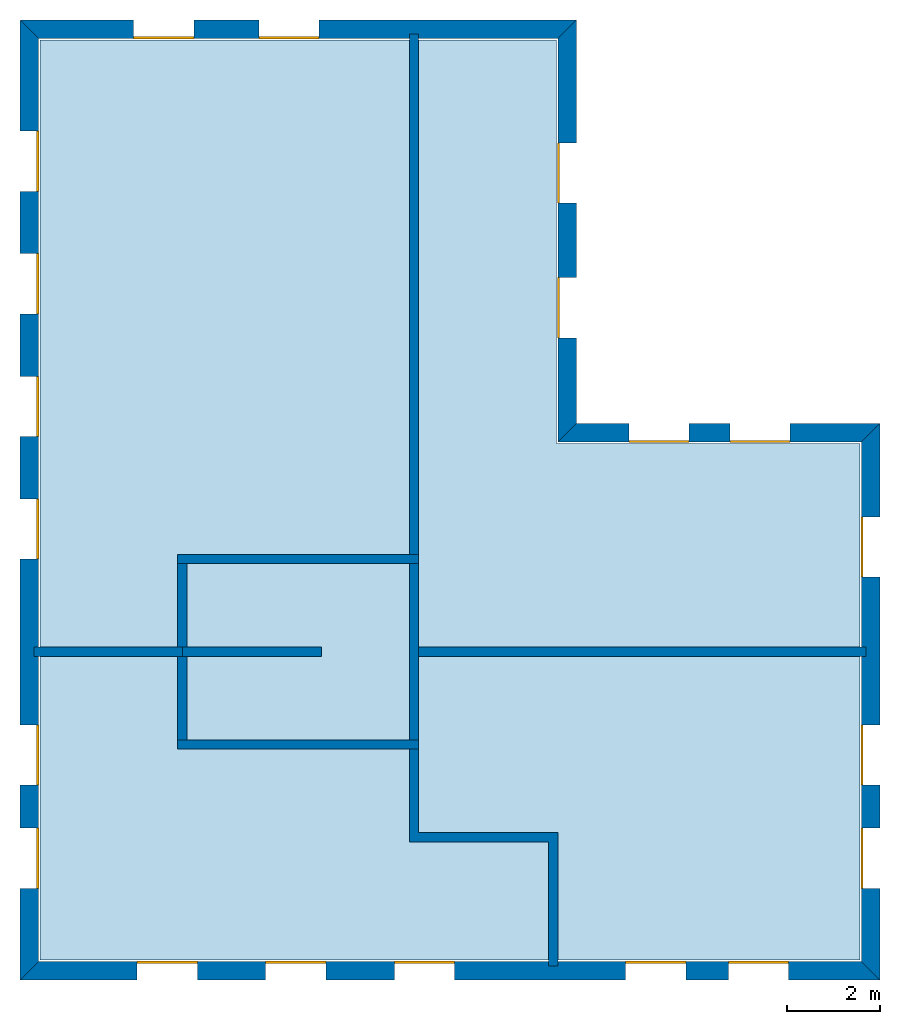
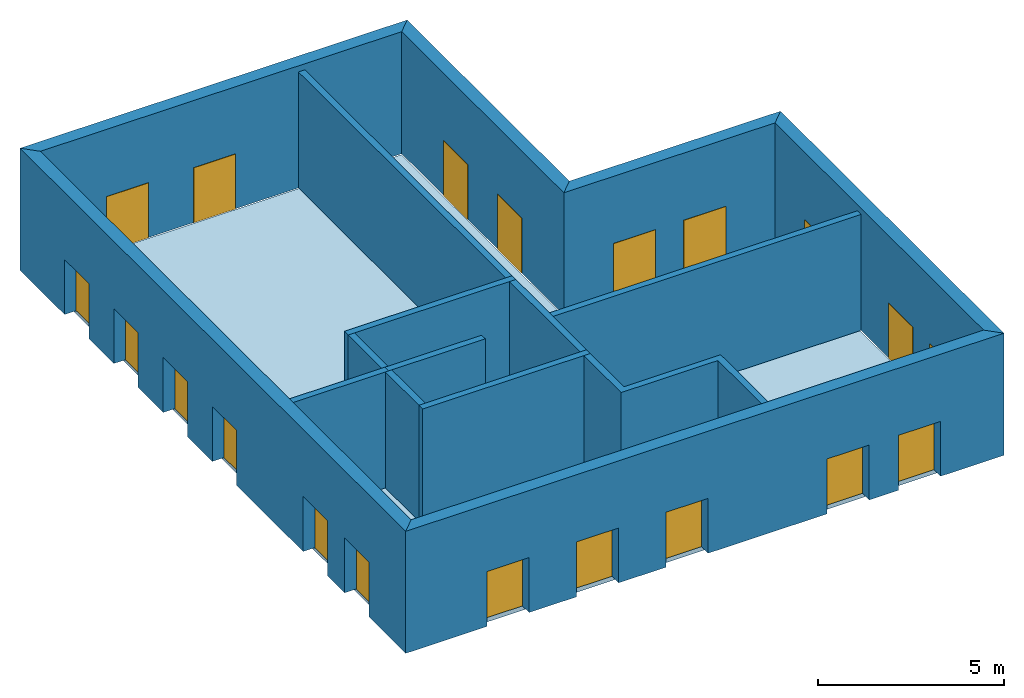
# One storey: 20 windows, 15 walls, 1 slab, 20 openings.
"""IFC4 building model written with IfcOpenShell, lengths in metres."""

from ifc_helpers import new_model, si_unit, origin_with_axes, place, context, subcontext, project, spatial, line, indexed_curve, outline, extrude, element, fill, save


model = new_model("IFC4")

# Units and contexts
model_context = context("Model", 3, precision=1e-05, world=origin_with_axes())
body_context = subcontext(model_context, "Body", "Model", "MODEL_VIEW")
ifc_project = project(units=[si_unit("VOLUMEUNIT", "CUBIC_METRE"), si_unit("LENGTHUNIT", "METRE"), si_unit("AREAUNIT", "SQUARE_METRE")], contexts=[model_context])

# Site, building, storey
site = spatial("IfcSite", under=ifc_project)
building = spatial("IfcBuilding", under=site, Name="Building 2")
storey_placement = place(None, origin_with_axes())
storey = spatial("IfcBuildingStorey", under=building, at=storey_placement, Name="01 Storey")

# Slab
slab_placement = place(storey_placement, origin_with_axes())
element("IfcSlab", 1, at=slab_placement, inside=storey, Name="Slab", context=body_context, shape_type="SweptSolid", body=[
    extrude(outline(indexed_curve([(22.109464, -3.589175), (15.563354, -3.589175), (15.563354, 5.1182), (4.423354, 5.1182), (4.423354, -14.729175), (22.109464, -14.729175)], segments=[line(1, 2), line(2, 3), line(3, 4), line(4, 5), line(5, 6)])), origin_with_axes(), (0.0, 0.0, -1.0), 0.2),
])

# Walls
wall_1_placement = place(storey_placement, origin_with_axes())
element("IfcWall", 2, at=wall_1_placement, inside=storey, Name="Wall", context=body_context, shape_type="SweptSolid", body=[
    extrude(outline(indexed_curve([(7.593354, -7.978543), (4.293354, -7.978543), (4.293354, -8.178543), (7.593354, -8.178543)], segments=[line(1, 2), line(2, 3), line(3, 4)])), origin_with_axes(), (0.0, 0.0, 1.0), 3.8),
])
wall_2_placement = place(storey_placement, origin_with_axes())
element("IfcWall", 3, at=wall_2_placement, inside=storey, Name="Wall", context=body_context, shape_type="SweptSolid", body=[
    extrude(outline(indexed_curve([(12.593354, 5.2482), (12.393354, 5.2482), (12.393354, -6.178543), (12.593354, -6.178543)], segments=[line(1, 2), line(2, 3), line(3, 4)])), origin_with_axes(), (0.0, 0.0, 1.0), 3.8),
])
wall_3_placement = place(storey_placement, origin_with_axes())
element("IfcWall", 4, at=wall_3_placement, inside=storey, Name="Wall", context=body_context, shape_type="SweptSolid", body=[
    extrude(outline(indexed_curve([(22.239464, -7.978543), (12.393354, -7.978543), (12.393354, -8.178543), (22.239464, -8.178543)], segments=[line(1, 2), line(2, 3), line(3, 4)])), origin_with_axes(), (0.0, 0.0, 1.0), 3.8),
])
wall_4_placement = place(storey_placement, origin_with_axes())
element("IfcWall", 5, at=wall_4_placement, inside=storey, Name="Wall", context=body_context, shape_type="SweptSolid", body=[
    extrude(outline(indexed_curve([(15.593354, -11.978543), (12.593354, -11.978543), (12.593354, -9.978543), (12.393354, -9.978543), (12.393354, -12.178543), (15.393354, -12.178543), (15.393354, -14.859175), (15.593354, -14.859175)], segments=[line(1, 2), line(2, 3), line(3, 4), line(4, 5), line(5, 6), line(6, 7), line(7, 8)])), origin_with_axes(), (0.0, 0.0, 1.0), 3.8),
])

# Wall, openings, windows
wall_5_placement = place(storey_placement, origin_with_axes())
wall_5 = element("IfcWall", 6, at=wall_5_placement, inside=storey, Name="Facade", context=body_context, shape_type="SweptSolid", body=[
    extrude(outline(indexed_curve([(22.139464, -3.559175), (15.593354, -3.559175), (15.993354, -3.159175), (22.539464, -3.159175)], segments=[line(1, 2), line(2, 3), line(3, 4)])), origin_with_axes(), (0.0, 0.0, 1.0), 4.0),
])
opening_1_placement = place(wall_5_placement, origin_with_axes())
opening_1 = element("IfcOpeningElement", 7, at=opening_1_placement, cuts=wall_5, Name="Opening", context=body_context, shape_type="SweptSolid", body=[
    extrude(outline(indexed_curve([(20.6074273333333, -3.119175), (20.6074273333333, -3.619175), (19.3074273333333, -3.619175), (19.3074273333333, -3.119175)], segments=[line(1, 2), line(2, 3), line(3, 4)])), origin_with_axes(), (0.0, 0.0, 1.0), 1.8),
])
opening_2_placement = place(wall_5_placement, origin_with_axes())
opening_2 = element("IfcOpeningElement", 8, at=opening_2_placement, cuts=wall_5, Name="Opening", context=body_context, shape_type="SweptSolid", body=[
    extrude(outline(indexed_curve([(18.4253906666667, -3.119175), (18.4253906666667, -3.619175), (17.1253906666667, -3.619175), (17.1253906666667, -3.119175)], segments=[line(1, 2), line(2, 3), line(3, 4)])), origin_with_axes(), (0.0, 0.0, 1.0), 1.8),
])
window_1_placement = place(storey_placement, origin_with_axes())
window_1 = element("IfcWindow", 9, at=window_1_placement, inside=storey, Name="Window", PredefinedType="WINDOW", context=body_context, shape_type="SweptSolid", body=[
    extrude(outline(indexed_curve([(20.6074273333333, -3.519175), (20.6074273333333, -3.569175), (19.3074273333333, -3.569175), (19.3074273333333, -3.519175)], segments=[line(1, 2), line(2, 3), line(3, 4)])), origin_with_axes(), (0.0, 0.0, 1.0), 1.8),
])
fill(opening_1, window_1)
window_2_placement = place(storey_placement, origin_with_axes())
window_2 = element("IfcWindow", 10, at=window_2_placement, inside=storey, Name="Window", PredefinedType="WINDOW", context=body_context, shape_type="SweptSolid", body=[
    extrude(outline(indexed_curve([(18.4253906666667, -3.519175), (18.4253906666667, -3.569175), (17.1253906666667, -3.569175), (17.1253906666667, -3.519175)], segments=[line(1, 2), line(2, 3), line(3, 4)])), origin_with_axes(), (0.0, 0.0, 1.0), 1.8),
])
fill(opening_2, window_2)

wall_6_placement = place(storey_placement, origin_with_axes())
wall_6 = element("IfcWall", 11, at=wall_6_placement, inside=storey, Name="Facade", context=body_context, shape_type="SweptSolid", body=[
    extrude(outline(indexed_curve([(15.593354, -3.559175), (15.593354, 5.1482), (15.993354, 5.5482), (15.993354, -3.159175)], segments=[line(1, 2), line(2, 3), line(3, 4)])), origin_with_axes(), (0.0, 0.0, 1.0), 4.0),
])
opening_3_placement = place(wall_6_placement, origin_with_axes())
opening_3 = element("IfcOpeningElement", 12, at=opening_3_placement, cuts=wall_6, Name="Opening", context=body_context, shape_type="SweptSolid", body=[
    extrude(outline(indexed_curve([(16.033354, -1.30671666666667), (15.533354, -1.30671666666667), (15.533354, -0.00671666666666659), (16.033354, -0.00671666666666659)], segments=[line(1, 2), line(2, 3), line(3, 4)])), origin_with_axes(), (0.0, 0.0, 1.0), 1.8),
])
opening_4_placement = place(wall_6_placement, origin_with_axes())
opening_4 = element("IfcOpeningElement", 13, at=opening_4_placement, cuts=wall_6, Name="Opening", context=body_context, shape_type="SweptSolid", body=[
    extrude(outline(indexed_curve([(16.033354, 1.59574166666667), (15.533354, 1.59574166666667), (15.533354, 2.89574166666667), (16.033354, 2.89574166666667)], segments=[line(1, 2), line(2, 3), line(3, 4)])), origin_with_axes(), (0.0, 0.0, 1.0), 1.8),
])
window_3_placement = place(storey_placement, origin_with_axes())
window_3 = element("IfcWindow", 14, at=window_3_placement, inside=storey, Name="Window", PredefinedType="WINDOW", context=body_context, shape_type="SweptSolid", body=[
    extrude(outline(indexed_curve([(15.633354, -1.30671666666667), (15.583354, -1.30671666666667), (15.583354, -0.00671666666666659), (15.633354, -0.00671666666666659)], segments=[line(1, 2), line(2, 3), line(3, 4)])), origin_with_axes(), (0.0, 0.0, 1.0), 1.8),
])
fill(opening_3, window_3)
window_4_placement = place(storey_placement, origin_with_axes())
window_4 = element("IfcWindow", 15, at=window_4_placement, inside=storey, Name="Window", PredefinedType="WINDOW", context=body_context, shape_type="SweptSolid", body=[
    extrude(outline(indexed_curve([(15.633354, 1.59574166666667), (15.583354, 1.59574166666667), (15.583354, 2.89574166666667), (15.633354, 2.89574166666667)], segments=[line(1, 2), line(2, 3), line(3, 4)])), origin_with_axes(), (0.0, 0.0, 1.0), 1.8),
])
fill(opening_4, window_4)

wall_7_placement = place(storey_placement, origin_with_axes())
wall_7 = element("IfcWall", 16, at=wall_7_placement, inside=storey, Name="Facade", context=body_context, shape_type="SweptSolid", body=[
    extrude(outline(indexed_curve([(15.593354, 5.1482), (4.393354, 5.1482), (3.993354, 5.5482), (15.993354, 5.5482)], segments=[line(1, 2), line(2, 3), line(3, 4)])), origin_with_axes(), (0.0, 0.0, 1.0), 4.0),
])
opening_5_placement = place(wall_7_placement, origin_with_axes())
opening_5 = element("IfcOpeningElement", 17, at=opening_5_placement, cuts=wall_7, Name="Opening", context=body_context, shape_type="SweptSolid", body=[
    extrude(outline(indexed_curve([(10.443354, 5.5882), (10.443354, 5.0882), (9.143354, 5.0882), (9.143354, 5.5882)], segments=[line(1, 2), line(2, 3), line(3, 4)])), origin_with_axes(), (0.0, 0.0, 1.0), 1.8),
])
opening_6_placement = place(wall_7_placement, origin_with_axes())
opening_6 = element("IfcOpeningElement", 18, at=opening_6_placement, cuts=wall_7, Name="Opening", context=body_context, shape_type="SweptSolid", body=[
    extrude(outline(indexed_curve([(7.743354, 5.5882), (7.743354, 5.0882), (6.443354, 5.0882), (6.443354, 5.5882)], segments=[line(1, 2), line(2, 3), line(3, 4)])), origin_with_axes(), (0.0, 0.0, 1.0), 1.8),
])
window_5_placement = place(storey_placement, origin_with_axes())
window_5 = element("IfcWindow", 19, at=window_5_placement, inside=storey, Name="Window", PredefinedType="WINDOW", context=body_context, shape_type="SweptSolid", body=[
    extrude(outline(indexed_curve([(10.443354, 5.1882), (10.443354, 5.1382), (9.143354, 5.1382), (9.143354, 5.1882)], segments=[line(1, 2), line(2, 3), line(3, 4)])), origin_with_axes(), (0.0, 0.0, 1.0), 1.8),
])
fill(opening_5, window_5)
window_6_placement = place(storey_placement, origin_with_axes())
window_6 = element("IfcWindow", 20, at=window_6_placement, inside=storey, Name="Window", PredefinedType="WINDOW", context=body_context, shape_type="SweptSolid", body=[
    extrude(outline(indexed_curve([(7.743354, 5.1882), (7.743354, 5.1382), (6.443354, 5.1382), (6.443354, 5.1882)], segments=[line(1, 2), line(2, 3), line(3, 4)])), origin_with_axes(), (0.0, 0.0, 1.0), 1.8),
])
fill(opening_6, window_6)

wall_8_placement = place(storey_placement, origin_with_axes())
wall_8 = element("IfcWall", 21, at=wall_8_placement, inside=storey, Name="Facade", context=body_context, shape_type="SweptSolid", body=[
    extrude(outline(indexed_curve([(4.393354, 5.1482), (4.393354, -14.759175), (3.993354, -15.159175), (3.993354, 5.5482)], segments=[line(1, 2), line(2, 3), line(3, 4)])), origin_with_axes(), (0.0, 0.0, 1.0), 4.0),
])
opening_7_placement = place(wall_8_placement, origin_with_axes())
opening_7 = element("IfcOpeningElement", 22, at=opening_7_placement, cuts=wall_8, Name="Opening", context=body_context, shape_type="SweptSolid", body=[
    extrude(outline(indexed_curve([(3.953354, 3.1528514), (4.453354, 3.1528514), (4.453354, 1.8528514), (3.953354, 1.8528514)], segments=[line(1, 2), line(2, 3), line(3, 4)])), origin_with_axes(), (0.0, 0.0, 1.0), 1.8),
])
opening_8_placement = place(wall_8_placement, origin_with_axes())
opening_8 = element("IfcOpeningElement", 23, at=opening_8_placement, cuts=wall_8, Name="Opening", context=body_context, shape_type="SweptSolid", body=[
    extrude(outline(indexed_curve([(3.953354, 0.507502800000001), (4.453354, 0.507502800000001), (4.453354, -0.792497199999999), (3.953354, -0.792497199999999)], segments=[line(1, 2), line(2, 3), line(3, 4)])), origin_with_axes(), (0.0, 0.0, 1.0), 1.8),
])
opening_9_placement = place(wall_8_placement, origin_with_axes())
opening_9 = element("IfcOpeningElement", 24, at=opening_9_placement, cuts=wall_8, Name="Opening", context=body_context, shape_type="SweptSolid", body=[
    extrude(outline(indexed_curve([(3.953354, -2.1378458), (4.453354, -2.1378458), (4.453354, -3.4378458), (3.953354, -3.4378458)], segments=[line(1, 2), line(2, 3), line(3, 4)])), origin_with_axes(), (0.0, 0.0, 1.0), 1.8),
])
opening_10_placement = place(wall_8_placement, origin_with_axes())
opening_10 = element("IfcOpeningElement", 25, at=opening_10_placement, cuts=wall_8, Name="Opening", context=body_context, shape_type="SweptSolid", body=[
    extrude(outline(indexed_curve([(3.953354, -4.7831944), (4.453354, -4.7831944), (4.453354, -6.0831944), (3.953354, -6.0831944)], segments=[line(1, 2), line(2, 3), line(3, 4)])), origin_with_axes(), (0.0, 0.0, 1.0), 1.8),
])
opening_11_placement = place(wall_8_placement, origin_with_axes())
opening_11 = element("IfcOpeningElement", 26, at=opening_11_placement, cuts=wall_8, Name="Opening", context=body_context, shape_type="SweptSolid", body=[
    extrude(outline(indexed_curve([(3.953354, -9.65542033333333), (4.453354, -9.65542033333333), (4.453354, -10.9554203333333), (3.953354, -10.9554203333333)], segments=[line(1, 2), line(2, 3), line(3, 4)])), origin_with_axes(), (0.0, 0.0, 1.0), 1.8),
])
opening_12_placement = place(wall_8_placement, origin_with_axes())
opening_12 = element("IfcOpeningElement", 27, at=opening_12_placement, cuts=wall_8, Name="Opening", context=body_context, shape_type="SweptSolid", body=[
    extrude(outline(indexed_curve([(3.953354, -11.8822976666667), (4.453354, -11.8822976666667), (4.453354, -13.1822976666667), (3.953354, -13.1822976666667)], segments=[line(1, 2), line(2, 3), line(3, 4)])), origin_with_axes(), (0.0, 0.0, 1.0), 1.8),
])
window_7_placement = place(storey_placement, origin_with_axes())
window_7 = element("IfcWindow", 28, at=window_7_placement, inside=storey, Name="Window", PredefinedType="WINDOW", context=body_context, shape_type="SweptSolid", body=[
    extrude(outline(indexed_curve([(4.353354, 3.1528514), (4.403354, 3.1528514), (4.403354, 1.8528514), (4.353354, 1.8528514)], segments=[line(1, 2), line(2, 3), line(3, 4)])), origin_with_axes(), (0.0, 0.0, 1.0), 1.8),
])
fill(opening_7, window_7)
window_8_placement = place(storey_placement, origin_with_axes())
window_8 = element("IfcWindow", 29, at=window_8_placement, inside=storey, Name="Window", PredefinedType="WINDOW", context=body_context, shape_type="SweptSolid", body=[
    extrude(outline(indexed_curve([(4.353354, 0.507502800000001), (4.403354, 0.507502800000001), (4.403354, -0.792497199999999), (4.353354, -0.792497199999999)], segments=[line(1, 2), line(2, 3), line(3, 4)])), origin_with_axes(), (0.0, 0.0, 1.0), 1.8),
])
fill(opening_8, window_8)
window_9_placement = place(storey_placement, origin_with_axes())
window_9 = element("IfcWindow", 30, at=window_9_placement, inside=storey, Name="Window", PredefinedType="WINDOW", context=body_context, shape_type="SweptSolid", body=[
    extrude(outline(indexed_curve([(4.353354, -2.1378458), (4.403354, -2.1378458), (4.403354, -3.4378458), (4.353354, -3.4378458)], segments=[line(1, 2), line(2, 3), line(3, 4)])), origin_with_axes(), (0.0, 0.0, 1.0), 1.8),
])
fill(opening_9, window_9)
window_10_placement = place(storey_placement, origin_with_axes())
window_10 = element("IfcWindow", 31, at=window_10_placement, inside=storey, Name="Window", PredefinedType="WINDOW", context=body_context, shape_type="SweptSolid", body=[
    extrude(outline(indexed_curve([(4.353354, -4.7831944), (4.403354, -4.7831944), (4.403354, -6.0831944), (4.353354, -6.0831944)], segments=[line(1, 2), line(2, 3), line(3, 4)])), origin_with_axes(), (0.0, 0.0, 1.0), 1.8),
])
fill(opening_10, window_10)
window_11_placement = place(storey_placement, origin_with_axes())
window_11 = element("IfcWindow", 32, at=window_11_placement, inside=storey, Name="Window", PredefinedType="WINDOW", context=body_context, shape_type="SweptSolid", body=[
    extrude(outline(indexed_curve([(4.353354, -9.65542033333333), (4.403354, -9.65542033333333), (4.403354, -10.9554203333333), (4.353354, -10.9554203333333)], segments=[line(1, 2), line(2, 3), line(3, 4)])), origin_with_axes(), (0.0, 0.0, 1.0), 1.8),
])
fill(opening_11, window_11)
window_12_placement = place(storey_placement, origin_with_axes())
window_12 = element("IfcWindow", 33, at=window_12_placement, inside=storey, Name="Window", PredefinedType="WINDOW", context=body_context, shape_type="SweptSolid", body=[
    extrude(outline(indexed_curve([(4.353354, -11.8822976666667), (4.403354, -11.8822976666667), (4.403354, -13.1822976666667), (4.353354, -13.1822976666667)], segments=[line(1, 2), line(2, 3), line(3, 4)])), origin_with_axes(), (0.0, 0.0, 1.0), 1.8),
])
fill(opening_12, window_12)

wall_9_placement = place(storey_placement, origin_with_axes())
wall_9 = element("IfcWall", 34, at=wall_9_placement, inside=storey, Name="Facade", context=body_context, shape_type="SweptSolid", body=[
    extrude(outline(indexed_curve([(4.393354, -14.759175), (22.139464, -14.759175), (22.539464, -15.159175), (3.993354, -15.159175)], segments=[line(1, 2), line(2, 3), line(3, 4)])), origin_with_axes(), (0.0, 0.0, 1.0), 4.0),
])
opening_13_placement = place(wall_9_placement, origin_with_axes())
opening_13 = element("IfcOpeningElement", 35, at=opening_13_placement, cuts=wall_9, Name="Opening", context=body_context, shape_type="SweptSolid", body=[
    extrude(outline(indexed_curve([(17.058724, -15.199175), (17.058724, -14.699175), (18.358724, -14.699175), (18.358724, -15.199175)], segments=[line(1, 2), line(2, 3), line(3, 4)])), origin_with_axes(), (0.0, 0.0, 1.0), 1.8),
])
opening_14_placement = place(wall_9_placement, origin_with_axes())
opening_14 = element("IfcOpeningElement", 36, at=opening_14_placement, cuts=wall_9, Name="Opening", context=body_context, shape_type="SweptSolid", body=[
    extrude(outline(indexed_curve([(19.274094, -15.199175), (19.274094, -14.699175), (20.574094, -14.699175), (20.574094, -15.199175)], segments=[line(1, 2), line(2, 3), line(3, 4)])), origin_with_axes(), (0.0, 0.0, 1.0), 1.8),
])
opening_15_placement = place(wall_9_placement, origin_with_axes())
opening_15 = element("IfcOpeningElement", 37, at=opening_15_placement, cuts=wall_9, Name="Opening", context=body_context, shape_type="SweptSolid", body=[
    extrude(outline(indexed_curve([(6.518354, -15.199175), (6.518354, -14.699175), (7.818354, -14.699175), (7.818354, -15.199175)], segments=[line(1, 2), line(2, 3), line(3, 4)])), origin_with_axes(), (0.0, 0.0, 1.0), 1.8),
])
opening_16_placement = place(wall_9_placement, origin_with_axes())
opening_16 = element("IfcOpeningElement", 38, at=opening_16_placement, cuts=wall_9, Name="Opening", context=body_context, shape_type="SweptSolid", body=[
    extrude(outline(indexed_curve([(9.293354, -15.199175), (9.293354, -14.699175), (10.593354, -14.699175), (10.593354, -15.199175)], segments=[line(1, 2), line(2, 3), line(3, 4)])), origin_with_axes(), (0.0, 0.0, 1.0), 1.8),
])
opening_17_placement = place(wall_9_placement, origin_with_axes())
opening_17 = element("IfcOpeningElement", 39, at=opening_17_placement, cuts=wall_9, Name="Opening", context=body_context, shape_type="SweptSolid", body=[
    extrude(outline(indexed_curve([(12.068354, -15.199175), (12.068354, -14.699175), (13.368354, -14.699175), (13.368354, -15.199175)], segments=[line(1, 2), line(2, 3), line(3, 4)])), origin_with_axes(), (0.0, 0.0, 1.0), 1.8),
])
window_13_placement = place(storey_placement, origin_with_axes())
window_13 = element("IfcWindow", 40, at=window_13_placement, inside=storey, Name="Window", PredefinedType="WINDOW", context=body_context, shape_type="SweptSolid", body=[
    extrude(outline(indexed_curve([(17.058724, -14.799175), (17.058724, -14.749175), (18.358724, -14.749175), (18.358724, -14.799175)], segments=[line(1, 2), line(2, 3), line(3, 4)])), origin_with_axes(), (0.0, 0.0, 1.0), 1.8),
])
fill(opening_13, window_13)
window_14_placement = place(storey_placement, origin_with_axes())
window_14 = element("IfcWindow", 41, at=window_14_placement, inside=storey, Name="Window", PredefinedType="WINDOW", context=body_context, shape_type="SweptSolid", body=[
    extrude(outline(indexed_curve([(19.274094, -14.799175), (19.274094, -14.749175), (20.574094, -14.749175), (20.574094, -14.799175)], segments=[line(1, 2), line(2, 3), line(3, 4)])), origin_with_axes(), (0.0, 0.0, 1.0), 1.8),
])
fill(opening_14, window_14)
window_15_placement = place(storey_placement, origin_with_axes())
window_15 = element("IfcWindow", 42, at=window_15_placement, inside=storey, Name="Window", PredefinedType="WINDOW", context=body_context, shape_type="SweptSolid", body=[
    extrude(outline(indexed_curve([(6.518354, -14.799175), (6.518354, -14.749175), (7.818354, -14.749175), (7.818354, -14.799175)], segments=[line(1, 2), line(2, 3), line(3, 4)])), origin_with_axes(), (0.0, 0.0, 1.0), 1.8),
])
fill(opening_15, window_15)
window_16_placement = place(storey_placement, origin_with_axes())
window_16 = element("IfcWindow", 43, at=window_16_placement, inside=storey, Name="Window", PredefinedType="WINDOW", context=body_context, shape_type="SweptSolid", body=[
    extrude(outline(indexed_curve([(9.293354, -14.799175), (9.293354, -14.749175), (10.593354, -14.749175), (10.593354, -14.799175)], segments=[line(1, 2), line(2, 3), line(3, 4)])), origin_with_axes(), (0.0, 0.0, 1.0), 1.8),
])
fill(opening_16, window_16)
window_17_placement = place(storey_placement, origin_with_axes())
window_17 = element("IfcWindow", 44, at=window_17_placement, inside=storey, Name="Window", PredefinedType="WINDOW", context=body_context, shape_type="SweptSolid", body=[
    extrude(outline(indexed_curve([(12.068354, -14.799175), (12.068354, -14.749175), (13.368354, -14.749175), (13.368354, -14.799175)], segments=[line(1, 2), line(2, 3), line(3, 4)])), origin_with_axes(), (0.0, 0.0, 1.0), 1.8),
])
fill(opening_17, window_17)

wall_10_placement = place(storey_placement, origin_with_axes())
wall_10 = element("IfcWall", 45, at=wall_10_placement, inside=storey, Name="Facade", context=body_context, shape_type="SweptSolid", body=[
    extrude(outline(indexed_curve([(22.139464, -14.759175), (22.139464, -3.559175), (22.539464, -3.159175), (22.539464, -15.159175)], segments=[line(1, 2), line(2, 3), line(3, 4)])), origin_with_axes(), (0.0, 0.0, 1.0), 4.0),
])
opening_18_placement = place(wall_10_placement, origin_with_axes())
opening_18 = element("IfcOpeningElement", 46, at=opening_18_placement, cuts=wall_10, Name="Opening", context=body_context, shape_type="SweptSolid", body=[
    extrude(outline(indexed_curve([(22.579464, -6.468859), (22.079464, -6.468859), (22.079464, -5.168859), (22.579464, -5.168859)], segments=[line(1, 2), line(2, 3), line(3, 4)])), origin_with_axes(), (0.0, 0.0, 1.0), 1.8),
])
opening_19_placement = place(wall_10_placement, origin_with_axes())
opening_19 = element("IfcOpeningElement", 47, at=opening_19_placement, cuts=wall_10, Name="Opening", context=body_context, shape_type="SweptSolid", body=[
    extrude(outline(indexed_curve([(22.579464, -13.1822976666667), (22.079464, -13.1822976666667), (22.079464, -11.8822976666667), (22.579464, -11.8822976666667)], segments=[line(1, 2), line(2, 3), line(3, 4)])), origin_with_axes(), (0.0, 0.0, 1.0), 1.8),
])
opening_20_placement = place(wall_10_placement, origin_with_axes())
opening_20 = element("IfcOpeningElement", 48, at=opening_20_placement, cuts=wall_10, Name="Opening", context=body_context, shape_type="SweptSolid", body=[
    extrude(outline(indexed_curve([(22.579464, -10.9554203333333), (22.079464, -10.9554203333333), (22.079464, -9.65542033333333), (22.579464, -9.65542033333333)], segments=[line(1, 2), line(2, 3), line(3, 4)])), origin_with_axes(), (0.0, 0.0, 1.0), 1.8),
])
window_18_placement = place(storey_placement, origin_with_axes())
window_18 = element("IfcWindow", 49, at=window_18_placement, inside=storey, Name="Window", PredefinedType="WINDOW", context=body_context, shape_type="SweptSolid", body=[
    extrude(outline(indexed_curve([(22.179464, -6.468859), (22.129464, -6.468859), (22.129464, -5.168859), (22.179464, -5.168859)], segments=[line(1, 2), line(2, 3), line(3, 4)])), origin_with_axes(), (0.0, 0.0, 1.0), 1.8),
])
fill(opening_18, window_18)
window_19_placement = place(storey_placement, origin_with_axes())
window_19 = element("IfcWindow", 50, at=window_19_placement, inside=storey, Name="Window", PredefinedType="WINDOW", context=body_context, shape_type="SweptSolid", body=[
    extrude(outline(indexed_curve([(22.179464, -13.1822976666667), (22.129464, -13.1822976666667), (22.129464, -11.8822976666667), (22.179464, -11.8822976666667)], segments=[line(1, 2), line(2, 3), line(3, 4)])), origin_with_axes(), (0.0, 0.0, 1.0), 1.8),
])
fill(opening_19, window_19)
window_20_placement = place(storey_placement, origin_with_axes())
window_20 = element("IfcWindow", 51, at=window_20_placement, inside=storey, Name="Window", PredefinedType="WINDOW", context=body_context, shape_type="SweptSolid", body=[
    extrude(outline(indexed_curve([(22.179464, -10.9554203333333), (22.129464, -10.9554203333333), (22.129464, -9.65542033333333), (22.179464, -9.65542033333333)], segments=[line(1, 2), line(2, 3), line(3, 4)])), origin_with_axes(), (0.0, 0.0, 1.0), 1.8),
])
fill(opening_20, window_20)

# Walls
wall_11_placement = place(storey_placement, origin_with_axes())
element("IfcWall", 52, at=wall_11_placement, inside=storey, Name="CoreWall", context=body_context, shape_type="SweptSolid", body=[
    extrude(outline(indexed_curve([(12.593354, -5.978543), (7.393354, -5.978543), (7.393354, -6.178543), (12.593354, -6.178543)], segments=[line(1, 2), line(2, 3), line(3, 4)])), origin_with_axes(), (0.0, 0.0, 1.0), 3.8),
])
wall_12_placement = place(storey_placement, origin_with_axes())
element("IfcWall", 53, at=wall_12_placement, inside=storey, Name="CoreWall", context=body_context, shape_type="SweptSolid", body=[
    extrude(outline(indexed_curve([(7.393354, -10.178543), (12.593354, -10.178543), (12.593354, -9.978543), (7.393354, -9.978543)], segments=[line(1, 2), line(2, 3), line(3, 4)])), origin_with_axes(), (0.0, 0.0, 1.0), 3.8),
])
wall_13_placement = place(storey_placement, origin_with_axes())
element("IfcWall", 54, at=wall_13_placement, inside=storey, Name="CoreWall", context=body_context, shape_type="SweptSolid", body=[
    extrude(outline(indexed_curve([(7.593354, -9.978543), (7.593354, -6.178543), (7.393354, -6.178543), (7.393354, -9.978543)], segments=[line(1, 2), line(2, 3), line(3, 4)])), origin_with_axes(), (0.0, 0.0, 1.0), 3.8),
])
wall_14_placement = place(storey_placement, origin_with_axes())
element("IfcWall", 55, at=wall_14_placement, inside=storey, Name="CoreWall", context=body_context, shape_type="SweptSolid", body=[
    extrude(outline(indexed_curve([(12.393354, -6.178543), (12.393354, -9.978543), (12.593354, -9.978543), (12.593354, -6.178543)], segments=[line(1, 2), line(2, 3), line(3, 4)])), origin_with_axes(), (0.0, 0.0, 1.0), 3.8),
])
wall_15_placement = place(storey_placement, origin_with_axes())
element("IfcWall", 56, at=wall_15_placement, inside=storey, Name="CoreWall", context=body_context, shape_type="SweptSolid", body=[
    extrude(outline(indexed_curve([(10.493354, -7.978543), (7.493354, -7.978543), (7.493354, -8.178543), (10.493354, -8.178543)], segments=[line(1, 2), line(2, 3), line(3, 4)])), origin_with_axes(), (0.0, 0.0, 1.0), 3.8),
])

save(model, "model.ifc")
